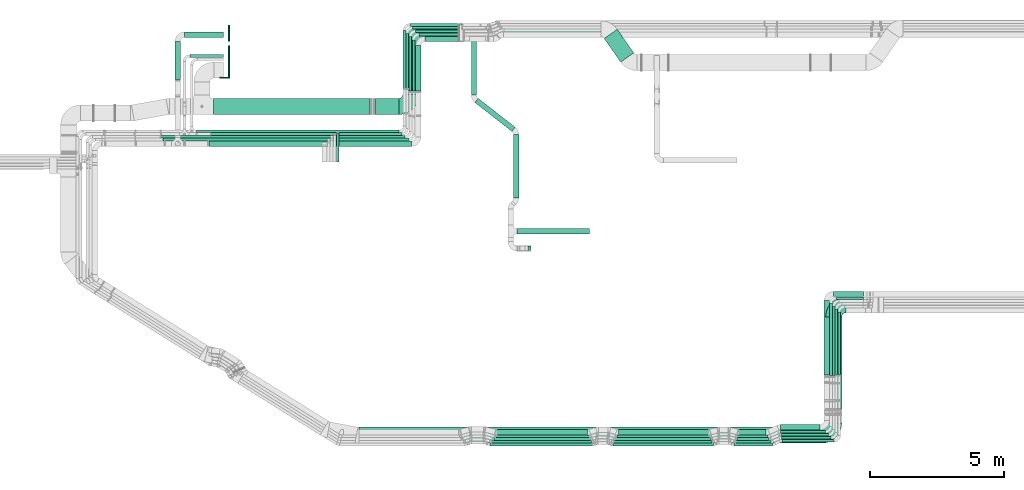
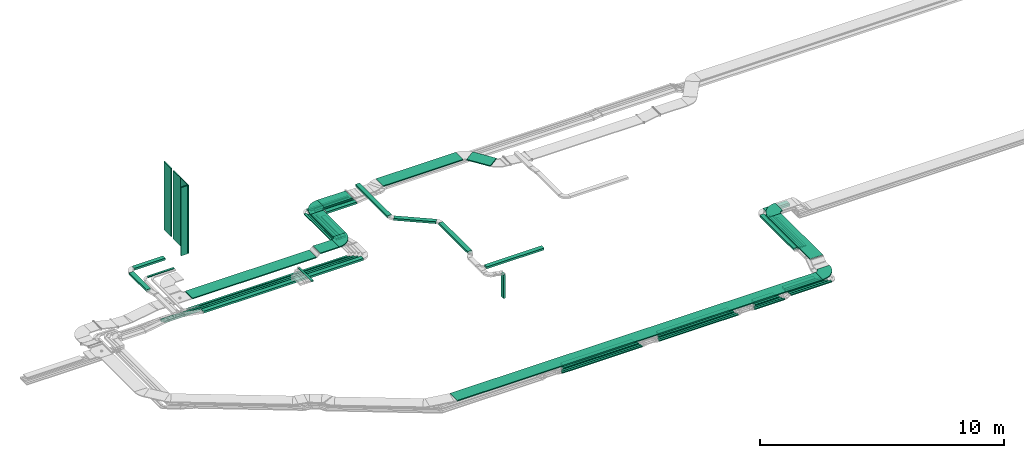
# One storey, part 3 of 28: 63 flow segments, 4 flow fittings.
"""IFC2X3 building model written with IfcOpenShell, lengths in millimetres."""

from ifc_helpers import new_model, entity, si_unit, converted_unit, derived_unit, direction, frame, frame_2d, origin, origin_2d_with_axis, place, context, subcontext, project, spatial, polyline, circle_curve, parameter, trimmed, segment, composite_curve, rectangle, outline, extrude, source, transform, mapped, material, type_object, type_shapes, element, save


model = new_model("IFC2X3")

# Units and contexts
model_context = context("Model", 3, precision=0.01, world=origin(), true_north=direction((6.12303176911189e-17, 1.0)))
body_context = subcontext(model_context, "Body", "Model", "MODEL_VIEW")
ifc_project = project(units=[si_unit("LENGTHUNIT", "METRE", prefix="MILLI"), si_unit("AREAUNIT", "SQUARE_METRE"), si_unit("VOLUMEUNIT", "CUBIC_METRE"), converted_unit("PLANEANGLEUNIT", "DEGREE", entity("IfcRatioMeasure", 0.0174532925199433), si_unit("PLANEANGLEUNIT", "RADIAN"), dimensions=[0, 0, 0, 0, 0, 0, 0]), si_unit("MASSUNIT", "GRAM", prefix="KILO"), derived_unit("MASSDENSITYUNIT", [(si_unit("MASSUNIT", "GRAM", prefix="KILO"), 1), (si_unit("LENGTHUNIT", "METRE"), -3)]), derived_unit("MOMENTOFINERTIAUNIT", [(si_unit("LENGTHUNIT", "METRE"), 4)]), si_unit("TIMEUNIT", "SECOND"), si_unit("FREQUENCYUNIT", "HERTZ"), si_unit("THERMODYNAMICTEMPERATUREUNIT", "DEGREE_CELSIUS"), derived_unit("THERMALTRANSMITTANCEUNIT", [(si_unit("MASSUNIT", "GRAM", prefix="KILO"), 1), (si_unit("THERMODYNAMICTEMPERATUREUNIT", "KELVIN"), -1), (si_unit("TIMEUNIT", "SECOND"), -3)]), derived_unit("VOLUMETRICFLOWRATEUNIT", [(si_unit("LENGTHUNIT", "METRE"), 3), (si_unit("TIMEUNIT", "SECOND"), -1)]), derived_unit("MASSFLOWRATEUNIT", [(si_unit("MASSUNIT", "GRAM", prefix="KILO"), 1), (si_unit("TIMEUNIT", "SECOND"), -1)]), derived_unit("ROTATIONALFREQUENCYUNIT", [(si_unit("TIMEUNIT", "SECOND"), -1)]), si_unit("ELECTRICCURRENTUNIT", "AMPERE"), si_unit("ELECTRICVOLTAGEUNIT", "VOLT"), si_unit("POWERUNIT", "WATT"), si_unit("FORCEUNIT", "NEWTON", prefix="KILO"), si_unit("ILLUMINANCEUNIT", "LUX"), si_unit("LUMINOUSFLUXUNIT", "LUMEN"), si_unit("LUMINOUSINTENSITYUNIT", "CANDELA"), derived_unit("USERDEFINED", [(si_unit("MASSUNIT", "GRAM", prefix="KILO"), -1), (si_unit("LENGTHUNIT", "METRE"), -2), (si_unit("TIMEUNIT", "SECOND"), 3), (si_unit("LUMINOUSFLUXUNIT", "LUMEN"), 1)]), derived_unit("LINEARVELOCITYUNIT", [(si_unit("LENGTHUNIT", "METRE"), 1), (si_unit("TIMEUNIT", "SECOND"), -1)]), si_unit("PRESSUREUNIT", "PASCAL"), derived_unit("USERDEFINED", [(si_unit("LENGTHUNIT", "METRE"), -2), (si_unit("MASSUNIT", "GRAM", prefix="KILO"), 1), (si_unit("TIMEUNIT", "SECOND"), -2)]), derived_unit("LINEARFORCEUNIT", [(si_unit("MASSUNIT", "GRAM", prefix="KILO"), 1), (si_unit("LENGTHUNIT", "METRE"), 1), (si_unit("TIMEUNIT", "SECOND"), -2), (si_unit("LENGTHUNIT", "METRE"), -1)]), derived_unit("PLANARFORCEUNIT", [(si_unit("MASSUNIT", "GRAM", prefix="KILO"), 1), (si_unit("LENGTHUNIT", "METRE"), 1), (si_unit("TIMEUNIT", "SECOND"), -2), (si_unit("LENGTHUNIT", "METRE"), -2)])], contexts=[model_context])

# Site, building, storey
site_placement = place(None, origin())
site = spatial("IfcSite", under=ifc_project, at=site_placement, CompositionType="ELEMENT")
building_placement = place(site_placement, origin())
building = spatial("IfcBuilding", under=site, at=building_placement, CompositionType="ELEMENT")
storey_placement = place(building_placement, frame((0.0, 0.0, 4200.0)))
storey = spatial("IfcBuildingStorey", under=building, at=storey_placement, CompositionType="ELEMENT", Elevation=4200.0)

# Flow segments
cable_carrier_segment_type_1 = type_object("IfcCableCarrierSegmentType", PredefinedType="CABLETRAYSEGMENT")
flow_segment_1_placement = place(storey_placement, frame((30526.43, 14592.48, 2793.21)))
element("IfcFlowSegment", 1, at=flow_segment_1_placement, inside=storey, type_object=cable_carrier_segment_type_1, context=body_context, shape_type="SweptSolid", body=[
    extrude(rectangle(XDim=1076.8183356809, YDim=600.000000000004, at=origin_2d_with_axis()), frame((554.56, 613.11, 0.0), z_axis=(0.0, 0.0, 1.0), x_axis=(0.573576436351025, -0.819152044289006, 0.0)), (0.0, 0.0, 1.0), 49.9999999999994),
])
flow_segment_2_placement = place(storey_placement, frame((26622.13, 15539.35, 2793.21)))
element("IfcFlowSegment", 2, at=flow_segment_2_placement, inside=storey, type_object=cable_carrier_segment_type_1, context=body_context, shape_type="SweptSolid", body=[
    extrude(rectangle(XDim=3779.85414124522, YDim=599.999999999998, at=origin_2d_with_axis()), frame((1889.93, 300.0, 0.0), z_axis=(0.0, 0.0, 1.0), x_axis=(-1.0, 0.0, 0.0)), (0.0, 0.0, 1.0), 49.9999999999995),
])
flow_segment_3_placement = place(storey_placement, frame((23749.99, 15379.35, 2823.52)))
element("IfcFlowSegment", 3, at=flow_segment_3_placement, inside=storey, type_object=cable_carrier_segment_type_1, context=body_context, shape_type="SweptSolid", body=[
    extrude(rectangle(XDim=1336.47856825049, YDim=599.999999999998, at=origin_2d_with_axis()), frame((668.24, 300.0, 0.0), z_axis=(0.0, 0.0, 1.0), x_axis=(-1.0, 0.0, 0.0)), (0.0, 0.0, 1.0), 49.9999999999995),
])
flow_segment_4_placement = place(storey_placement, frame((23478.99, 13508.36, 2524.49)))
element("IfcFlowSegment", 4, at=flow_segment_4_placement, inside=storey, type_object=cable_carrier_segment_type_1, context=body_context, shape_type="SweptSolid", body=[
    extrude(rectangle(XDim=1696.30769414965, YDim=199.999999999998, at=origin_2d_with_axis()), frame((100.0, 848.15, 0.0), z_axis=(0.0, 0.0, 1.0), x_axis=(0.0, 1.0, 0.0)), (0.0, 0.0, 1.0), 99.9999999999989),
])
flow_segment_5_placement = place(storey_placement, frame((23604.07, 15574.48, 2520.16)))
element("IfcFlowSegment", 5, at=flow_segment_5_placement, inside=storey, type_object=cable_carrier_segment_type_1, context=body_context, shape_type="SweptSolid", body=[
    extrude(rectangle(XDim=1663.41414412451, YDim=99.9999999999989, at=origin_2d_with_axis()), frame((831.71, 50.0, 0.0)), (0.0, 0.0, 1.0), 99.9999999999989),
])
flow_segment_6_placement = place(storey_placement, frame((23353.07, 13504.72, 2520.16)))
element("IfcFlowSegment", 6, at=flow_segment_6_placement, inside=storey, type_object=cable_carrier_segment_type_1, context=body_context, shape_type="SweptSolid", body=[
    extrude(rectangle(XDim=1918.7534875651, YDim=100.000000000003, at=origin_2d_with_axis()), frame((50.0, 959.38, 0.0), z_axis=(0.0, 0.0, 1.0), x_axis=(0.0, 1.0, 0.0)), (0.0, 0.0, 1.0), 99.9999999999989),
])
flow_segment_7_placement = place(storey_placement, frame((23479.87, 15694.48, 2524.49)))
element("IfcFlowSegment", 7, at=flow_segment_7_placement, inside=storey, type_object=cable_carrier_segment_type_1, context=body_context, shape_type="SweptSolid", body=[
    extrude(rectangle(XDim=1787.61492232689, YDim=99.9999999999989, at=origin_2d_with_axis()), frame((893.81, 50.0, 0.0)), (0.0, 0.0, 1.0), 100.000000000001),
])
flow_segment_8_placement = place(storey_placement, frame((23228.87, 13511.14, 2524.49)))
element("IfcFlowSegment", 8, at=flow_segment_8_placement, inside=storey, type_object=cable_carrier_segment_type_1, context=body_context, shape_type="SweptSolid", body=[
    extrude(rectangle(XDim=2032.33894814533, YDim=100.000000000003, at=origin_2d_with_axis()), frame((50.0, 1016.17, 0.0), z_axis=(0.0, 0.0, 1.0), x_axis=(0.0, 1.0, 0.0)), (0.0, 0.0, 1.0), 99.9999999999989),
])
flow_segment_9_placement = place(storey_placement, frame((23364.07, 15820.66, 2524.49)))
element("IfcFlowSegment", 9, at=flow_segment_9_placement, inside=storey, type_object=cable_carrier_segment_type_1, context=body_context, shape_type="SweptSolid", body=[
    extrude(rectangle(XDim=1830.52522556067, YDim=99.9999999999989, at=origin_2d_with_axis()), frame((915.26, 50.0, 0.0)), (0.0, 0.0, 1.0), 49.9999999999995),
])
flow_segment_10_placement = place(storey_placement, frame((23113.07, 13606.28, 2524.49)))
element("IfcFlowSegment", 10, at=flow_segment_10_placement, inside=storey, type_object=cable_carrier_segment_type_1, context=body_context, shape_type="SweptSolid", body=[
    extrude(rectangle(XDim=2063.38546449354, YDim=100.000000000003, at=origin_2d_with_axis()), frame((50.0, 1031.69, 0.0), z_axis=(0.0, 0.0, 1.0), x_axis=(0.0, 1.0, 0.0)), (0.0, 0.0, 1.0), 50.0000000000005),
])
flow_segment_11_placement = place(storey_placement, frame((23008.87, 13606.28, 2524.49)))
element("IfcFlowSegment", 11, at=flow_segment_11_placement, inside=storey, type_object=cable_carrier_segment_type_1, context=body_context, shape_type="SweptSolid", body=[
    extrude(rectangle(XDim=2172.30851294771, YDim=100.000000000003, at=origin_2d_with_axis()), frame((50.0, 1086.15, 0.0), z_axis=(0.0, 0.0, 1.0), x_axis=(0.0, 1.0, 0.0)), (0.0, 0.0, 1.0), 50.0000000000005),
])
flow_segment_12_placement = place(storey_placement, frame((23829.99, 15355.66, 2524.49)))
element("IfcFlowSegment", 12, at=flow_segment_12_placement, inside=storey, type_object=cable_carrier_segment_type_1, context=body_context, shape_type="SweptSolid", body=[
    extrude(rectangle(XDim=1437.49142669443, YDim=200.000000000002, at=origin_2d_with_axis()), frame((718.75, 100.0, 0.0)), (0.0, 0.0, 1.0), 100.000000000001),
])
flow_segment_13_placement = place(storey_placement, frame((35501.05, 551.66, 2836.0)))
element("IfcFlowSegment", 13, at=flow_segment_13_placement, inside=storey, type_object=cable_carrier_segment_type_1, context=body_context, shape_type="SweptSolid", body=[
    extrude(rectangle(XDim=1159.34523094115, YDim=99.9999999999999, at=origin_2d_with_axis()), frame((579.67, 50.0, 0.0)), (0.0, 0.0, 1.0), 99.9999999999989),
])
flow_segment_14_placement = place(storey_placement, frame((35490.29, 446.66, 2836.0)))
element("IfcFlowSegment", 14, at=flow_segment_14_placement, inside=storey, type_object=cable_carrier_segment_type_1, context=body_context, shape_type="SweptSolid", body=[
    extrude(rectangle(XDim=1189.84057568571, YDim=100.0, at=origin_2d_with_axis()), frame((594.92, 50.0, 0.0)), (0.0, 0.0, 1.0), 100.000000000001),
])
flow_segment_15_placement = place(storey_placement, frame((39160.32, 2909.52, 3025.0)))
element("IfcFlowSegment", 15, at=flow_segment_15_placement, inside=storey, type_object=cable_carrier_segment_type_1, context=body_context, shape_type="SweptSolid", body=[
    extrude(rectangle(XDim=2444.67483897861, YDim=99.9999999999946, at=origin_2d_with_axis()), frame((50.0, 1222.34, 0.0), z_axis=(0.0, 0.0, 1.0), x_axis=(0.0, -1.0, 0.0)), (0.0, 0.0, 1.0), 49.9999999999995),
])
flow_segment_16_placement = place(storey_placement, frame((39265.32, 2909.52, 3025.0)))
element("IfcFlowSegment", 16, at=flow_segment_16_placement, inside=storey, type_object=cable_carrier_segment_type_1, context=body_context, shape_type="SweptSolid", body=[
    extrude(rectangle(XDim=2339.67483897862, YDim=99.9999999999946, at=origin_2d_with_axis()), frame((50.0, 1169.84, 0.0), z_axis=(0.0, 0.0, 1.0), x_axis=(0.0, -1.0, 0.0)), (0.0, 0.0, 1.0), 49.9999999999984),
])
flow_segment_17_placement = place(storey_placement, frame((38811.38, 1634.44, 3300.0)))
element("IfcFlowSegment", 17, at=flow_segment_17_placement, inside=storey, type_object=cable_carrier_segment_type_1, context=body_context, shape_type="SweptSolid", body=[
    extrude(rectangle(XDim=3431.21825406948, YDim=600.000000000002, at=origin_2d_with_axis()), frame((300.0, 1715.61, 0.0), z_axis=(0.0, 0.0, 1.0), x_axis=(0.0, -1.0, 0.0)), (0.0, 0.0, 1.0), 49.9999999999995),
])
flow_segment_18_placement = place(storey_placement, frame((39103.82, 5820.19, 3025.0)))
element("IfcFlowSegment", 18, at=flow_segment_18_placement, inside=storey, type_object=cable_carrier_segment_type_1, context=body_context, shape_type="SweptSolid", body=[
    extrude(rectangle(XDim=1117.36076727557, YDim=200.0, at=origin_2d_with_axis()), frame((558.68, 100.0, 0.0), z_axis=(0.0, 0.0, 1.0), x_axis=(-1.0, 0.0, 0.0)), (0.0, 0.0, 1.0), 99.9999999999989),
])
flow_segment_19_placement = place(storey_placement, frame((38752.82, 2892.35, 3025.2)))
element("IfcFlowSegment", 19, at=flow_segment_19_placement, inside=storey, type_object=cable_carrier_segment_type_1, context=body_context, shape_type="SweptSolid", body=[
    extrude(rectangle(XDim=2776.81466354588, YDim=199.999999999998, at=origin_2d_with_axis()), frame((100.0, 1388.48, 0.96), z_axis=(0.0, -0.00069172506749642, 0.999999760758187), x_axis=(0.0, -0.999999760758187, -0.00069172506749642)), (0.0, 0.0, 1.0), 100.0),
])
flow_segment_20_placement = place(storey_placement, frame((15291.77, 11954.03, 2750.0)))
element("IfcFlowSegment", 20, at=flow_segment_20_placement, inside=storey, type_object=cable_carrier_segment_type_1, context=body_context, shape_type="SweptSolid", body=[
    extrude(rectangle(XDim=7566.10371603052, YDim=99.9999999999989, at=origin_2d_with_axis()), frame((3783.05, 50.0, 0.0), z_axis=(0.0, 0.0, 1.0), x_axis=(-1.0, 0.0, 0.0)), (0.0, 0.0, 1.0), 49.9999999999995),
])
flow_segment_21_placement = place(storey_placement, frame((15831.62, 11851.53, 2750.0)))
element("IfcFlowSegment", 21, at=flow_segment_21_placement, inside=storey, type_object=cable_carrier_segment_type_1, context=body_context, shape_type="SweptSolid", body=[
    extrude(rectangle(XDim=7130.45186392018, YDim=99.9999999999989, at=origin_2d_with_axis()), frame((3565.23, 50.0, 0.0), z_axis=(0.0, 0.0, 1.0), x_axis=(-1.0, 0.0, 0.0)), (0.0, 0.0, 1.0), 49.9999999999995),
])
flow_segment_22_placement = place(storey_placement, frame((13940.8, 11748.96, 2750.0)))
element("IfcFlowSegment", 22, at=flow_segment_22_placement, inside=storey, type_object=cable_carrier_segment_type_1, context=body_context, shape_type="SweptSolid", body=[
    extrude(rectangle(XDim=9137.0713587031, YDim=99.9999999999989, at=origin_2d_with_axis()), frame((4568.54, 50.0, 0.09), z_axis=(1.87970794353878e-05, 0.0, 1.0), x_axis=(-1.0, 0.0, 1.87970794353878e-05)), (0.0, 0.0, 1.0), 99.9999999999995),
])
flow_segment_23_placement = place(storey_placement, frame((26523.22, 646.66, 2836.0)))
element("IfcFlowSegment", 23, at=flow_segment_23_placement, inside=storey, type_object=cable_carrier_segment_type_1, context=body_context, shape_type="SweptSolid", body=[
    extrude(rectangle(XDim=3385.56862737912, YDim=200.0, at=origin_2d_with_axis()), frame((1692.78, 100.0, 0.0)), (0.0, 0.0, 1.0), 99.9999999999989),
])
flow_segment_24_placement = place(storey_placement, frame((26257.07, 246.66, 2836.0)))
element("IfcFlowSegment", 24, at=flow_segment_24_placement, inside=storey, type_object=cable_carrier_segment_type_1, context=body_context, shape_type="SweptSolid", body=[
    extrude(rectangle(XDim=3827.37771721429, YDim=100.0, at=origin_2d_with_axis()), frame((1913.69, 50.0, 0.0)), (0.0, 0.0, 1.0), 50.0000000000005),
])
flow_segment_25_placement = place(storey_placement, frame((26323.72, 346.66, 2836.0)))
element("IfcFlowSegment", 25, at=flow_segment_25_placement, inside=storey, type_object=cable_carrier_segment_type_1, context=body_context, shape_type="SweptSolid", body=[
    extrude(rectangle(XDim=3735.72938775046, YDim=100.0, at=origin_2d_with_axis()), frame((1867.86, 50.0, 0.0)), (0.0, 0.0, 1.0), 49.9999999999995),
])
flow_segment_26_placement = place(storey_placement, frame((26407.29, 446.66, 2836.0)))
element("IfcFlowSegment", 26, at=flow_segment_26_placement, inside=storey, type_object=cable_carrier_segment_type_1, context=body_context, shape_type="SweptSolid", body=[
    extrude(rectangle(XDim=3607.07536972812, YDim=100.0, at=origin_2d_with_axis()), frame((1803.54, 50.0, 0.0)), (0.0, 0.0, 1.0), 100.000000000001),
])
flow_segment_27_placement = place(storey_placement, frame((26471.79, 546.66, 2836.0)))
element("IfcFlowSegment", 27, at=flow_segment_27_placement, inside=storey, type_object=cable_carrier_segment_type_1, context=body_context, shape_type="SweptSolid", body=[
    extrude(rectangle(XDim=3500.05490190336, YDim=100.0, at=origin_2d_with_axis()), frame((1750.03, 50.0, 0.0)), (0.0, 0.0, 1.0), 99.9999999999989),
])
flow_segment_28_placement = place(storey_placement, frame((31064.15, 646.66, 2836.0)))
element("IfcFlowSegment", 28, at=flow_segment_28_placement, inside=storey, type_object=cable_carrier_segment_type_1, context=body_context, shape_type="SweptSolid", body=[
    extrude(rectangle(XDim=3361.53433688883, YDim=200.0, at=origin_2d_with_axis()), frame((1680.77, 100.0, 0.0)), (0.0, 0.0, 1.0), 100.000000000001),
])
flow_segment_29_placement = place(storey_placement, frame((30849.54, 246.66, 2836.0)))
element("IfcFlowSegment", 29, at=flow_segment_29_placement, inside=storey, type_object=cable_carrier_segment_type_1, context=body_context, shape_type="SweptSolid", body=[
    extrude(rectangle(XDim=3769.83343954607, YDim=100.0, at=origin_2d_with_axis()), frame((1884.92, 50.0, 0.0)), (0.0, 0.0, 1.0), 49.9999999999995),
])
flow_segment_30_placement = place(storey_placement, frame((30877.28, 346.66, 2836.0)))
element("IfcFlowSegment", 30, at=flow_segment_30_placement, inside=storey, type_object=cable_carrier_segment_type_1, context=body_context, shape_type="SweptSolid", body=[
    extrude(rectangle(XDim=3689.36782997479, YDim=100.0, at=origin_2d_with_axis()), frame((1844.68, 50.0, 0.0)), (0.0, 0.0, 1.0), 49.9999999999995),
])
flow_segment_31_placement = place(storey_placement, frame((30932.47, 446.66, 2836.0)))
element("IfcFlowSegment", 31, at=flow_segment_31_placement, inside=storey, type_object=cable_carrier_segment_type_1, context=body_context, shape_type="SweptSolid", body=[
    extrude(rectangle(XDim=3591.78366611905, YDim=100.0, at=origin_2d_with_axis()), frame((1795.89, 50.0, 0.0)), (0.0, 0.0, 1.0), 99.9999999999989),
])
flow_segment_32_placement = place(storey_placement, frame((30999.9, 546.66, 2836.0)))
element("IfcFlowSegment", 32, at=flow_segment_32_placement, inside=storey, type_object=cable_carrier_segment_type_1, context=body_context, shape_type="SweptSolid", body=[
    extrude(rectangle(XDim=3479.44994453675, YDim=100.0, at=origin_2d_with_axis()), frame((1739.72, 50.0, 0.0)), (0.0, 0.0, 1.0), 99.9999999999989),
])
flow_segment_33_placement = place(storey_placement, frame((35576.89, 651.66, 2836.0)))
element("IfcFlowSegment", 33, at=flow_segment_33_placement, inside=storey, type_object=cable_carrier_segment_type_1, context=body_context, shape_type="SweptSolid", body=[
    extrude(rectangle(XDim=1004.34018748789, YDim=200.0, at=origin_2d_with_axis()), frame((502.17, 100.0, 0.0)), (0.0, 0.0, 1.0), 99.9999999999989),
])
flow_segment_34_placement = place(storey_placement, frame((35383.49, 246.66, 2836.0)))
element("IfcFlowSegment", 34, at=flow_segment_34_placement, inside=storey, type_object=cable_carrier_segment_type_1, context=body_context, shape_type="SweptSolid", body=[
    extrude(rectangle(XDim=1441.96076120629, YDim=100.0, at=origin_2d_with_axis()), frame((720.98, 50.0, 0.0)), (0.0, 0.0, 1.0), 49.9999999999995),
])
flow_segment_35_placement = place(storey_placement, frame((37174.41, 378.11, 2836.0)))
element("IfcFlowSegment", 35, at=flow_segment_35_placement, inside=storey, type_object=cable_carrier_segment_type_1, context=body_context, shape_type="SweptSolid", body=[
    extrude(rectangle(XDim=1939.91372405874, YDim=100.0, at=origin_2d_with_axis()), frame((969.96, 50.0, 0.0)), (0.0, 0.0, 1.0), 49.9999999999995),
])
flow_segment_36_placement = place(storey_placement, frame((35441.78, 346.66, 2836.0)))
element("IfcFlowSegment", 36, at=flow_segment_36_placement, inside=storey, type_object=cable_carrier_segment_type_1, context=body_context, shape_type="SweptSolid", body=[
    extrude(rectangle(XDim=1314.70372211323, YDim=100.0, at=origin_2d_with_axis()), frame((657.35, 50.0, 0.0)), (0.0, 0.0, 1.0), 49.9999999999995),
])
flow_segment_37_placement = place(storey_placement, frame((37155.31, 490.35, 2836.0)))
element("IfcFlowSegment", 37, at=flow_segment_37_placement, inside=storey, type_object=cable_carrier_segment_type_1, context=body_context, shape_type="SweptSolid", body=[
    extrude(rectangle(XDim=1854.01641987895, YDim=100.0, at=origin_2d_with_axis()), frame((927.01, 50.0, 0.0)), (0.0, 0.0, 1.0), 49.9999999999995),
])
flow_segment_38_placement = place(storey_placement, frame((37122.2, 837.25, 2836.0)))
element("IfcFlowSegment", 38, at=flow_segment_38_placement, inside=storey, type_object=cable_carrier_segment_type_1, context=body_context, shape_type="SweptSolid", body=[
    extrude(rectangle(XDim=1479.62592584546, YDim=200.0, at=origin_2d_with_axis()), frame((739.81, 100.0, 0.0)), (0.0, 0.0, 1.0), 99.9999999999989),
])
flow_segment_39_placement = place(storey_placement, frame((37121.0, 724.16, 2836.0)))
element("IfcFlowSegment", 39, at=flow_segment_39_placement, inside=storey, type_object=cable_carrier_segment_type_1, context=body_context, shape_type="SweptSolid", body=[
    extrude(rectangle(XDim=1683.51813446421, YDim=100.0, at=origin_2d_with_axis()), frame((841.76, 50.0, 0.0)), (0.0, 0.0, 1.0), 99.9999999999989),
])
flow_segment_40_placement = place(storey_placement, frame((39206.52, 5715.19, 3025.0)))
element("IfcFlowSegment", 40, at=flow_segment_40_placement, inside=storey, type_object=cable_carrier_segment_type_1, context=body_context, shape_type="SweptSolid", body=[
    extrude(rectangle(XDim=1014.66076623827, YDim=100.000000000001, at=origin_2d_with_axis()), frame((507.33, 50.0, 0.0), z_axis=(0.0, 0.0, 1.0), x_axis=(-1.0, 0.0, 0.0)), (0.0, 0.0, 1.0), 99.9999999999989),
])
flow_segment_41_placement = place(storey_placement, frame((38955.52, 2877.35, 3025.0)))
element("IfcFlowSegment", 41, at=flow_segment_41_placement, inside=storey, type_object=cable_carrier_segment_type_1, context=body_context, shape_type="SweptSolid", body=[
    extrude(rectangle(XDim=2686.84515364263, YDim=99.9999999999989, at=origin_2d_with_axis()), frame((50.0, 1343.42, 0.0), z_axis=(0.0, 0.0, 1.0), x_axis=(0.0, -1.0, 0.0)), (0.0, 0.0, 1.0), 99.9999999999989),
])
flow_segment_42_placement = place(storey_placement, frame((37150.12, 610.76, 2836.0)))
element("IfcFlowSegment", 42, at=flow_segment_42_placement, inside=storey, type_object=cable_carrier_segment_type_1, context=body_context, shape_type="SweptSolid", body=[
    extrude(rectangle(XDim=1757.69750166517, YDim=100.0, at=origin_2d_with_axis()), frame((878.85, 50.0, 0.0)), (0.0, 0.0, 1.0), 99.9999999999989),
])
flow_segment_43_placement = place(storey_placement, frame((39058.82, 2877.35, 3025.0)))
element("IfcFlowSegment", 43, at=flow_segment_43_placement, inside=storey, type_object=cable_carrier_segment_type_1, context=body_context, shape_type="SweptSolid", body=[
    extrude(rectangle(XDim=2581.84515364261, YDim=99.9999999999946, at=origin_2d_with_axis()), frame((50.0, 1290.92, 0.0), z_axis=(0.0, 0.0, 1.0), x_axis=(0.0, -1.0, 0.0)), (0.0, 0.0, 1.0), 100.000000000001),
])
flow_segment_44_placement = place(storey_placement, frame((21352.53, 341.66, 3108.85)))
element("IfcFlowSegment", 44, at=flow_segment_44_placement, inside=storey, type_object=cable_carrier_segment_type_1, context=body_context, shape_type="SweptSolid", body=[
    extrude(rectangle(XDim=17307.8588946513, YDim=600.0, at=origin_2d_with_axis()), frame((8653.93, 300.0, 0.0)), (0.0, 0.0, 1.0), 49.9999999999995),
])
flow_segment_45_placement = place(storey_placement, frame((15914.08, 12632.05, 2682.77)))
element("IfcFlowSegment", 45, at=flow_segment_45_placement, inside=storey, type_object=cable_carrier_segment_type_1, context=body_context, shape_type="SweptSolid", body=[
    extrude(rectangle(XDim=5857.91074407675, YDim=599.999999999998, at=origin_2d_with_axis()), frame((2928.96, 300.0, 0.0)), (0.0, 0.0, 1.0), 49.9999999999995),
])
flow_segment_46_placement = place(storey_placement, frame((22998.99, 13383.05, 2823.52)))
element("IfcFlowSegment", 46, at=flow_segment_46_placement, inside=storey, type_object=cable_carrier_segment_type_1, context=body_context, shape_type="SweptSolid", body=[
    extrude(rectangle(XDim=1845.29649822984, YDim=600.000000000002, at=origin_2d_with_axis()), frame((300.0, 922.65, 0.0), z_axis=(0.0, 0.0, 1.0), x_axis=(0.0, -1.0, 0.0)), (0.0, 0.0, 1.0), 49.9999999999995),
])
flow_segment_47_placement = place(storey_placement, frame((15034.07, 14768.13, 2750.0)))
element("IfcFlowSegment", 47, at=flow_segment_47_placement, inside=storey, type_object=cable_carrier_segment_type_1, context=body_context, shape_type="SweptSolid", body=[
    extrude(rectangle(XDim=1263.23547445559, YDim=99.9999999999989, at=origin_2d_with_axis()), frame((631.62, 50.0, 0.0)), (0.0, 0.0, 1.0), 49.9999999999984),
])
flow_segment_48_placement = place(storey_placement, frame((14834.54, 15518.13, 2753.82)))
element("IfcFlowSegment", 48, at=flow_segment_48_placement, inside=storey, type_object=cable_carrier_segment_type_1, context=body_context, shape_type="SweptSolid", body=[
    extrude(rectangle(XDim=1462.76506453108, YDim=200.000000000002, at=origin_2d_with_axis()), frame((731.38, 100.0, 0.0)), (0.0, 0.0, 1.0), 99.9999999999978),
])
flow_segment_49_placement = place(storey_placement, frame((14483.54, 13939.08, 2753.82)))
element("IfcFlowSegment", 49, at=flow_segment_49_placement, inside=storey, type_object=cable_carrier_segment_type_1, context=body_context, shape_type="SweptSolid", body=[
    extrude(rectangle(XDim=1428.04426852684, YDim=200.000000000002, at=origin_2d_with_axis()), frame((100.0, 714.02, 0.0), z_axis=(0.0, 0.0, 1.0), x_axis=(0.0, -1.0, 0.0)), (0.0, 0.0, 1.0), 99.9999999999989),
])
flow_segment_50_placement = place(storey_placement, frame((21968.3, 12632.05, 2823.52)))
element("IfcFlowSegment", 50, at=flow_segment_50_placement, inside=storey, type_object=cable_carrier_segment_type_1, context=body_context, shape_type="SweptSolid", body=[
    extrude(rectangle(XDim=879.692977941358, YDim=599.999999999998, at=origin_2d_with_axis()), frame((439.85, 300.0, 0.0)), (0.0, 0.0, 1.0), 49.9999999999984),
])
flow_segment_51_placement = place(storey_placement, frame((15744.89, 11443.79, 2750.0)))
element("IfcFlowSegment", 51, at=flow_segment_51_placement, inside=storey, type_object=cable_carrier_segment_type_1, context=body_context, shape_type="SweptSolid", body=[
    extrude(rectangle(XDim=7583.10332638238, YDim=200.000000000002, at=origin_2d_with_axis()), frame((3791.55, 100.0, 0.0), z_axis=(0.0, 0.0, 1.0), x_axis=(-1.0, 0.0, 0.0)), (0.0, 0.0, 1.0), 99.9999999999989),
])
flow_segment_52_placement = place(storey_placement, frame((14029.74, 11646.85, 2750.0)))
element("IfcFlowSegment", 52, at=flow_segment_52_placement, inside=storey, type_object=cable_carrier_segment_type_1, context=body_context, shape_type="SweptSolid", body=[
    extrude(rectangle(XDim=9172.33358705854, YDim=99.9999999999989, at=origin_2d_with_axis()), frame((4586.17, 50.0, 0.0), z_axis=(0.0, 0.0, 1.0), x_axis=(-1.0, 0.0, 0.0)), (0.0, 0.0, 1.0), 99.9999999999989),
])
flow_segment_53_placement = place(storey_placement, frame((23259.87, 15929.59, 2524.49)))
element("IfcFlowSegment", 53, at=flow_segment_53_placement, inside=storey, type_object=cable_carrier_segment_type_1, context=body_context, shape_type="SweptSolid", body=[
    extrude(rectangle(XDim=1953.64153674384, YDim=99.9999999999989, at=origin_2d_with_axis()), frame((976.82, 50.0, 0.0)), (0.0, 0.0, 1.0), 49.9999999999995),
])
flow_segment_54_placement = place(storey_placement, frame((20510.96, 10851.67, 3005.0)))
element("IfcFlowSegment", 54, at=flow_segment_54_placement, inside=storey, type_object=cable_carrier_segment_type_1, context=body_context, shape_type="SweptSolid", body=[
    extrude(rectangle(XDim=1092.35687357644, YDim=100.000000000003, at=origin_2d_with_axis()), frame((50.0, 546.18, 0.0), z_axis=(0.0, 0.0, 1.0), x_axis=(0.0, -1.0, 0.0)), (0.0, 0.0, 1.0), 50.0000000000005),
])
flow_segment_55_placement = place(storey_placement, frame((27134.06, 9508.58, 2930.0)))
element("IfcFlowSegment", 55, at=flow_segment_55_placement, inside=storey, type_object=cable_carrier_segment_type_1, context=body_context, shape_type="SweptSolid", body=[
    extrude(rectangle(XDim=2372.51346226528, YDim=199.999999999998, at=origin_2d_with_axis()), frame((100.0, 1186.26, 0.0), z_axis=(0.0, 0.0, 1.0), x_axis=(0.0, -1.0, 0.0)), (0.0, 0.0, 1.0), 99.9999999999989),
])
flow_segment_56_placement = place(storey_placement, frame((25693.34, 12000.91, 2930.0)))
element("IfcFlowSegment", 56, at=flow_segment_56_placement, inside=storey, type_object=cable_carrier_segment_type_1, context=body_context, shape_type="SweptSolid", body=[
    extrude(rectangle(XDim=1754.13370571707, YDim=200.000000000001, at=origin_2d_with_axis()), frame((752.7, 618.78, 0.0), z_axis=(0.0, 0.0, 1.0), x_axis=(-0.788010753606729, 0.615661475325649, 0.0)), (0.0, 0.0, 1.0), 99.9999999999989),
])
flow_segment_57_placement = place(storey_placement, frame((25558.04, 13358.29, 2930.0)))
element("IfcFlowSegment", 57, at=flow_segment_57_placement, inside=storey, type_object=cable_carrier_segment_type_1, context=body_context, shape_type="SweptSolid", body=[
    extrude(rectangle(XDim=2621.30000271867, YDim=199.999999999998, at=origin_2d_with_axis()), frame((100.0, 1310.65, 0.0), z_axis=(0.0, 0.0, 1.0), x_axis=(0.0, 1.0, 0.0)), (0.0, 0.0, 1.0), 99.9999999999989),
])
flow_segment_58_placement = place(storey_placement, frame((27261.22, 8163.8, 2930.0)))
element("IfcFlowSegment", 58, at=flow_segment_58_placement, inside=storey, type_object=cable_carrier_segment_type_1, context=body_context, shape_type="SweptSolid", body=[
    extrude(rectangle(XDim=2723.62339400056, YDim=200.0, at=origin_2d_with_axis()), frame((1361.81, 100.0, 0.0)), (0.0, 0.0, 1.0), 100.0),
])
flow_segment_59_placement = place(storey_placement, frame((27686.22, 7525.0, 1680.0)))
element("IfcFlowSegment", 59, at=flow_segment_59_placement, inside=storey, type_object=cable_carrier_segment_type_1, context=body_context, shape_type="SweptSolid", body=[
    extrude(rectangle(XDim=100.000000000003, YDim=200.0, at=origin_2d_with_axis()), frame((50.0, 100.0, 0.0)), (0.0, 0.0, 1.0), 1186.96103583828),
])
cable_carrier_segment_type_2 = type_object("IfcCableCarrierSegmentType", PredefinedType="CABLETRAYSEGMENT")
for number, where in (
    (60, (16472.31, 15367.61, 3945.84)),
    (61, (16472.31, 14607.61, 3945.84)),
):
    element("IfcFlowSegment", number, at=place(storey_placement, frame(where)), inside=storey, type_object=cable_carrier_segment_type_2, context=body_context, shape_type="SweptSolid", body=[
        extrude(rectangle(XDim=50.0000000000016, YDim=600.000000000002, at=origin_2d_with_axis()), frame((25.0, 300.0, 0.0), z_axis=(0.0, 0.0, 1.0), x_axis=(-1.0, 0.0, 0.0)), (0.0, 0.0, 1.0), 3420.0),
    ])
flow_segment_60_placement = place(storey_placement, frame((16472.31, 13987.61, 3945.84)))
element("IfcFlowSegment", 62, at=flow_segment_60_placement, inside=storey, type_object=cable_carrier_segment_type_2, context=body_context, shape_type="SweptSolid", body=[
    extrude(rectangle(XDim=50.0000000000016, YDim=599.999999999998, at=origin_2d_with_axis()), frame((25.0, 300.0, 0.0), z_axis=(0.0, 0.0, 1.0), x_axis=(-1.0, 0.0, 0.0)), (0.0, 0.0, 1.0), 3420.0),
])
flow_segment_61_placement = place(storey_placement, frame((16147.31, 13982.61, 3945.84)))
element("IfcFlowSegment", 63, at=flow_segment_61_placement, inside=storey, type_object=cable_carrier_segment_type_2, context=body_context, shape_type="SweptSolid", body=[
    extrude(rectangle(XDim=50.0000000000016, YDim=300.000000000001, at=origin_2d_with_axis()), frame((150.0, 25.0, 0.0), z_axis=(0.0, 0.0, 1.0), x_axis=(0.0, 1.0, 0.0)), (0.0, 0.0, 1.0), 3420.0),
])

# Flow fittings
ifc_material = material()
cable_carrier_fitting_type = type_object("IfcCableCarrierFittingType", Name="470_DKC_S5_Variable Angle Elbow 0-45:-", PredefinedType="NOTDEFINED", material=ifc_material)
shared_shape = source(origin(), body_context, "Body", "SweptSolid", [
    extrude(outline(composite_curve([segment(polyline([(-225.75, -525.25), (-224.75, -525.25)]), True, "CONTINUOUS"), segment(trimmed(circle_curve(frame_2d((-224.75, 224.75), x_axis=(0.0, -1.0)), 750.0), [parameter(0.0)], [parameter(90.0)], True, "PARAMETER"), True, "CONTINUOUS"), segment(polyline([(525.25, 224.75), (525.25, 225.75)]), True, "CONTINUOUS"), segment(polyline([(525.25, 225.75), (-74.75, 225.75)]), True, "CONTINUOUS"), segment(polyline([(-74.75, 225.75), (-74.75, 224.75)]), True, "CONTINUOUS"), segment(trimmed(circle_curve(frame_2d((-224.75, 224.75), x_axis=(0.0, -1.0)), 150.0), [parameter(0.0)], [parameter(90.0000000000001)], True, "PARAMETER"), False, "CONTINUOUS"), segment(polyline([(-224.75, 74.75), (-225.75, 74.75)]), True, "CONTINUOUS"), segment(polyline([(-225.75, 74.75), (-225.75, -525.25)]), True, "CONTINUOUS")], self_intersect=False)), frame((-225.25, 225.25, -25.0)), (0.0, 0.0, 1.0), 50.0000000000082),
])
type_shapes(cable_carrier_fitting_type, [shared_shape])
for number, where, z_axis, x_axis, name in (
    (64, (23298.99, 15679.35, 2848.52), (0.0, 0.0, 1.0), (-1.0, 0.0, 0.0), "470_DKC_S5_Variable Angle Elbow 0-45:-"),
    (65, (39111.38, 5516.66, 3325.0), (0.0, 0.0, 1.0), (-1.0, 0.0, 0.0), "470_DKC_S5_Variable Angle Elbow 0-45:-"),
):
    element("IfcFlowFitting", number, at=place(storey_placement, frame(where, z_axis=z_axis, x_axis=x_axis)), inside=storey, type_object=cable_carrier_fitting_type, material=ifc_material, Name=name, ObjectType="470_DKC_S5_Variable Angle Elbow 0-45:-", context=body_context, shape_type="MappedRepresentation", body=[
        mapped(shared_shape, transform((0.0, 0.0, 0.0), scale=1.0)),
    ])
for number, where, name in (
    (66, (39111.38, 641.66, 3133.85), "470_DKC_S5_Variable Angle Elbow 0-45:-"),
    (67, (23298.99, 12932.05, 2848.52), "470_DKC_S5_Variable Angle Elbow 0-45:-"),
):
    element("IfcFlowFitting", number, at=place(storey_placement, frame(where)), inside=storey, type_object=cable_carrier_fitting_type, material=ifc_material, Name=name, ObjectType="470_DKC_S5_Variable Angle Elbow 0-45:-", context=body_context, shape_type="MappedRepresentation", body=[
        mapped(shared_shape, transform((0.0, 0.0, 0.0), scale=1.0)),
    ])

save(model, "model.ifc")
